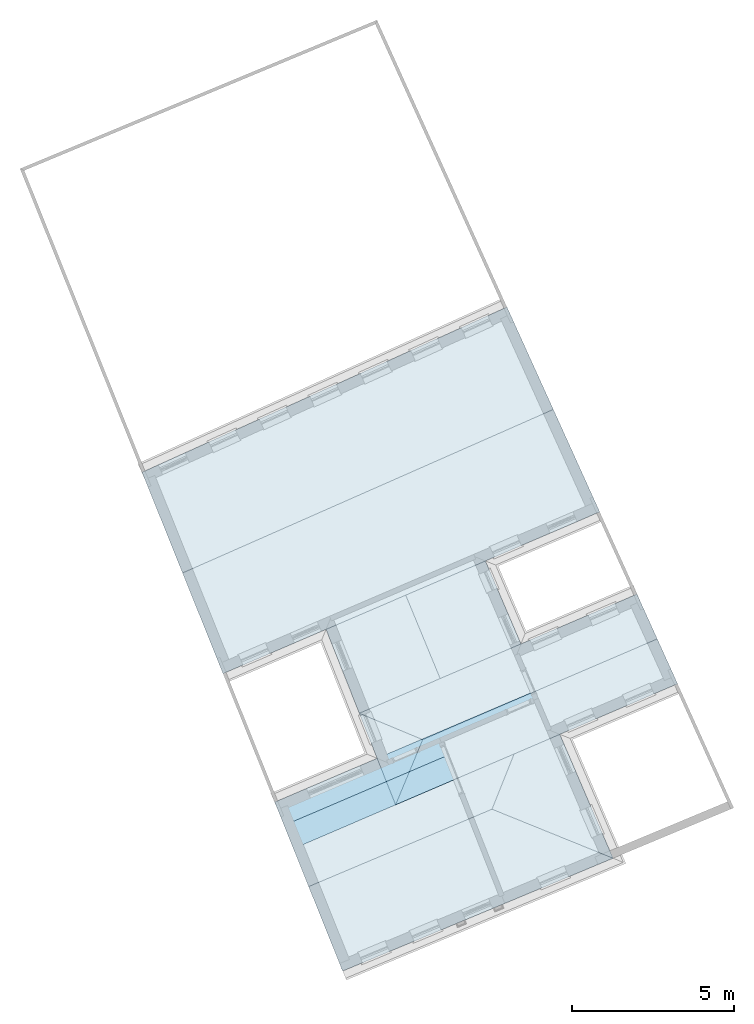
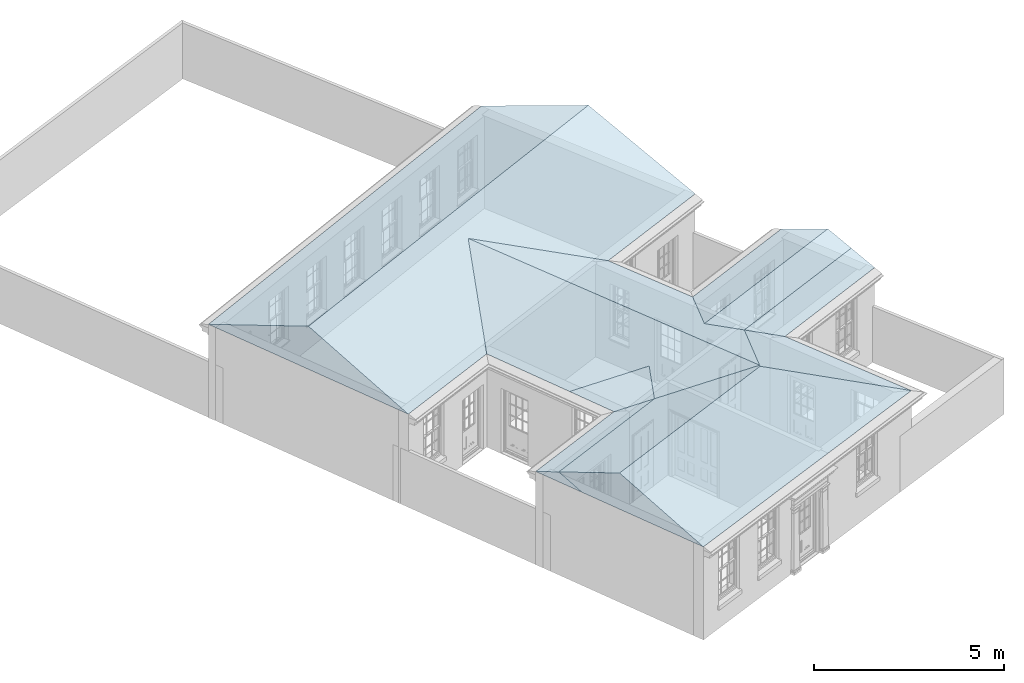
# One storey, part 18 of 19: 5 roofs.
"""IFC2X3 building model written with IfcOpenShell, lengths in metres."""

from ifc_helpers import new_model, si_unit, origin, place, context, subcontext, project, spatial, faceted_brep, element, save


model = new_model("IFC2X3")

# Units and contexts
model_context = context("Model", 3, world=origin())
body_context = subcontext(model_context, "Body", "Model", "MODEL_VIEW")
ifc_project = project(units=[si_unit("PLANEANGLEUNIT", "RADIAN"), si_unit("MASSUNIT", "GRAM", prefix="KILO"), si_unit("FORCEUNIT", "NEWTON", prefix="KILO"), si_unit("LENGTHUNIT", "METRE")], contexts=[model_context])

# Site, building, storey
site_placement = place(None, origin())
site = spatial("IfcSite", under=ifc_project, at=site_placement, CompositionType="ELEMENT")
building_placement = place(None, origin())
building = spatial("IfcBuilding", under=site, at=building_placement, Name="Building plot-0", CompositionType="ELEMENT")
storey_placement = place(None, origin())
storey = spatial("IfcBuildingStorey", under=building, at=storey_placement, Name="Floor 0", CompositionType="ELEMENT", Elevation=0.0)

# Roofs
roof_1_placement = place(building_placement, origin())
element("IfcRoof", 1, at=roof_1_placement, inside=storey, Name="Roof", ShapeType="FREEFORM", context=body_context, shape_type="Brep", held_by="IfcProductRepresentation", body=[
    faceted_brep([(24.638603, 23.679248, 3.0), (17.991739, 39.162067, 3.0), (16.640024, 35.677257, 4.083919), (20.980573, 25.161537, 4.150113), (13.288088, 37.031904, 3.0), (19.441074, 21.51053, 3.0)], [[[0, 1, 2, 3]], [[4, 5, 3, 2]], [[5, 4, 1, 0]], [[5, 0, 3]], [[1, 4, 2]]]),
])
roof_2_placement = place(building_placement, origin())
element("IfcRoof", 2, at=roof_2_placement, inside=storey, Name="Roof", ShapeType="FREEFORM", context=body_context, shape_type="Brep", held_by="IfcProductRepresentation", body=[
    faceted_brep([(12.603106, 29.376523, 3.0), (24.227847, 34.367091, 3.0), (22.796071, 37.528622, 4.437301), (11.354239, 32.48233, 4.386204), (21.364573, 40.689537, 3.0), (10.104556, 35.590164, 3.0)], [[[0, 1, 2, 3]], [[4, 5, 3, 2]], [[5, 4, 1, 0]], [[5, 0, 3]], [[1, 4, 2]]]),
])
roof_3_placement = place(building_placement, origin())
element("IfcRoof", 3, at=roof_3_placement, inside=storey, Name="Roof", ShapeType="FREEFORM", context=body_context, shape_type="Brep", held_by="IfcProductRepresentation", body=[
    faceted_brep([(22.392898, 28.910261, 3.0), (14.197021, 25.412621, 3.0), (15.245627, 22.804842, 4.163976), (20.903869, 25.192619, 4.174229), (16.294091, 20.197421, 3.0), (24.638603, 23.679248, 3.0)], [[[0, 1, 2, 3]], [[4, 5, 3, 2]], [[5, 4, 1, 0]], [[5, 0, 3]], [[1, 4, 2]]]),
])
roof_4_placement = place(building_placement, origin())
element("IfcRoof", 4, at=roof_4_placement, inside=storey, Name="Roof", ShapeType="FREEFORM", context=body_context, shape_type="Brep", held_by="IfcProductRepresentation", body=[
    faceted_brep([(17.928352, 25.326487, 3.0), (26.630265, 29.062268, 3.0), (26.003385, 30.446493, 3.629299), (18.764854, 27.33895, 3.629299), (25.376505, 31.830717, 3.0), (16.808153, 28.152274, 3.0)], [[[0, 1, 2, 3]], [[4, 5, 3, 2]], [[5, 4, 1, 0]], [[5, 0, 3]], [[1, 4, 2]]]),
])
roof_5_placement = place(building_placement, origin())
element("IfcRoof", 5, at=roof_5_placement, inside=storey, Name="Roof", ShapeType="FREEFORM", context=body_context, shape_type="Brep", held_by="IfcProductRepresentation", body=[
    faceted_brep([(14.775861, 23.973104, 3.0), (26.630265, 29.062268, 3.0), (26.315965, 29.756278, 3.315512), (14.486434, 24.69288, 3.321255), (26.001652, 30.450319, 3.0), (14.197021, 25.412621, 3.0)], [[[0, 1, 2, 3]], [[4, 5, 3, 2]], [[5, 4, 1, 0]], [[5, 0, 3]], [[1, 4, 2]]]),
])

save(model, "model.ifc")
